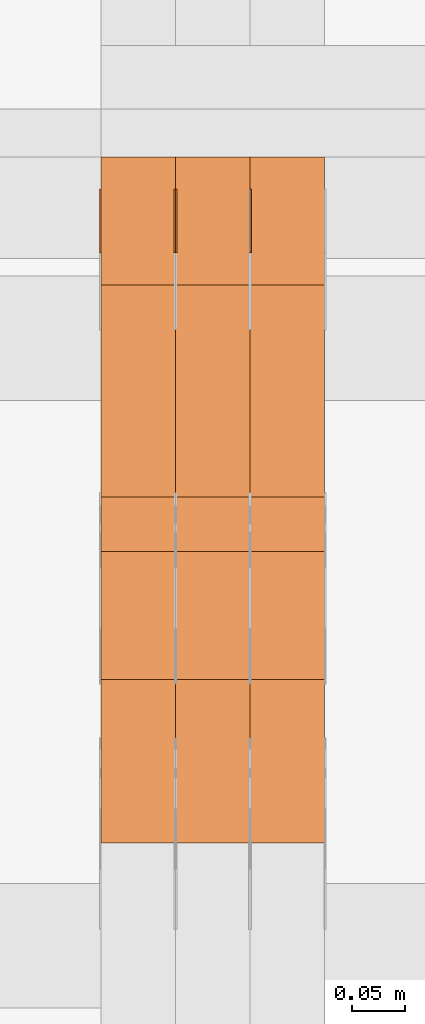
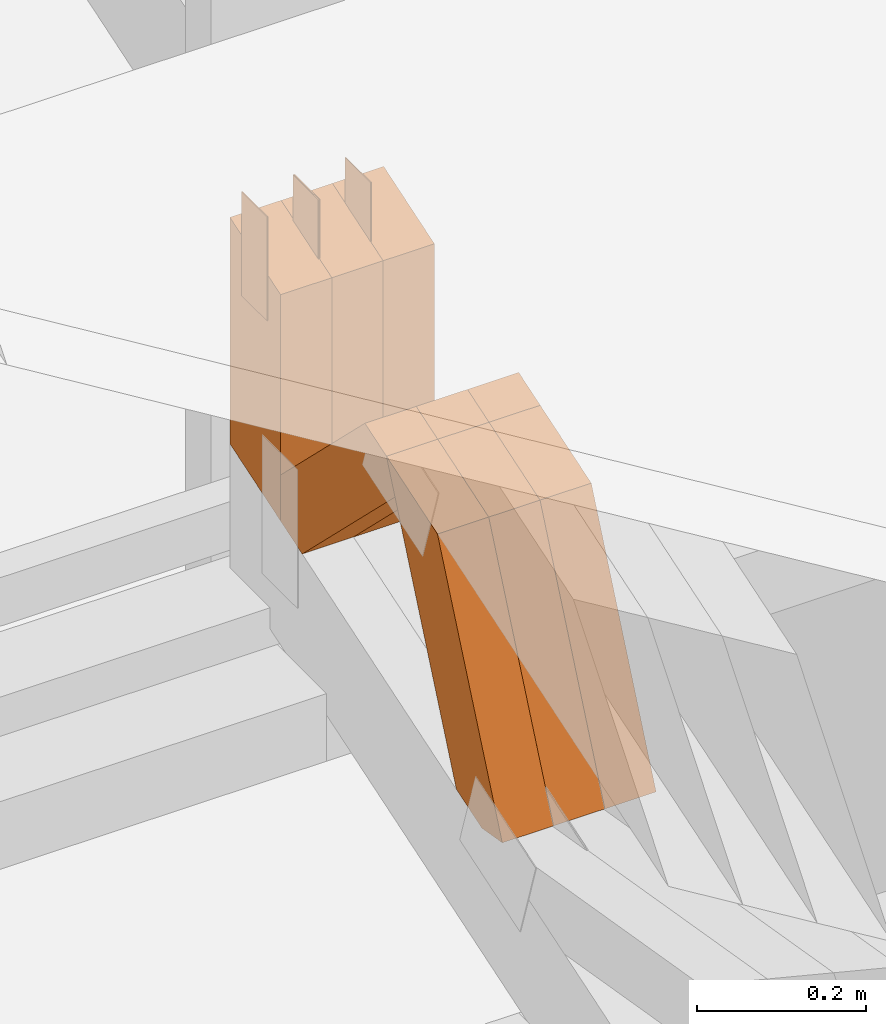
# One storey, part 98 of 385: 13 proxies.
"""IFC2X3 building model written with IfcOpenShell, lengths in millimetres."""

from ifc_helpers import new_model, entity, si_unit, converted_unit, derived_unit, direction, frame, origin, origin_2d_with_axis, place, context, subcontext, project, spatial, polyline, rectangle, outline, extrude, source, transform, mapped, material, type_object, type_shapes, element, save


model = new_model("IFC2X3")

# Units and contexts
model_context = context("Model", 3, precision=0.01, world=origin(), true_north=direction((6.12303176911189e-17, 1.0)))
body_context = subcontext(model_context, "Body", "Model", "MODEL_VIEW")
ifc_project = project(units=[si_unit("LENGTHUNIT", "METRE", prefix="MILLI"), si_unit("AREAUNIT", "SQUARE_METRE"), si_unit("VOLUMEUNIT", "CUBIC_METRE"), converted_unit("PLANEANGLEUNIT", "DEGREE", entity("IfcRatioMeasure", 0.0174532925199433), si_unit("PLANEANGLEUNIT", "RADIAN"), dimensions=[0, 0, 0, 0, 0, 0, 0]), si_unit("MASSUNIT", "GRAM", prefix="KILO"), derived_unit("MASSDENSITYUNIT", [(si_unit("MASSUNIT", "GRAM", prefix="KILO"), 1), (si_unit("LENGTHUNIT", "METRE"), -3)]), si_unit("TIMEUNIT", "SECOND"), si_unit("FREQUENCYUNIT", "HERTZ"), si_unit("THERMODYNAMICTEMPERATUREUNIT", "DEGREE_CELSIUS"), derived_unit("THERMALTRANSMITTANCEUNIT", [(si_unit("MASSUNIT", "GRAM", prefix="KILO"), 1), (si_unit("THERMODYNAMICTEMPERATUREUNIT", "KELVIN"), -1), (si_unit("TIMEUNIT", "SECOND"), -3)]), derived_unit("VOLUMETRICFLOWRATEUNIT", [(si_unit("LENGTHUNIT", "METRE"), 3), (si_unit("TIMEUNIT", "SECOND"), -1)]), si_unit("ELECTRICCURRENTUNIT", "AMPERE"), si_unit("ELECTRICVOLTAGEUNIT", "VOLT"), si_unit("POWERUNIT", "WATT"), si_unit("FORCEUNIT", "NEWTON", prefix="KILO"), si_unit("ILLUMINANCEUNIT", "LUX"), si_unit("LUMINOUSFLUXUNIT", "LUMEN"), si_unit("LUMINOUSINTENSITYUNIT", "CANDELA"), derived_unit("USERDEFINED", [(si_unit("MASSUNIT", "GRAM", prefix="KILO"), -1), (si_unit("LENGTHUNIT", "METRE"), -2), (si_unit("TIMEUNIT", "SECOND"), 3), (si_unit("LUMINOUSFLUXUNIT", "LUMEN"), 1)]), derived_unit("LINEARVELOCITYUNIT", [(si_unit("LENGTHUNIT", "METRE"), 1), (si_unit("TIMEUNIT", "SECOND"), -1)]), si_unit("PRESSUREUNIT", "PASCAL"), derived_unit("USERDEFINED", [(si_unit("LENGTHUNIT", "METRE"), -2), (si_unit("MASSUNIT", "GRAM", prefix="KILO"), 1), (si_unit("TIMEUNIT", "SECOND"), -2)])], contexts=[model_context])

# Site, building, storey
site_placement = place(None, origin())
site = spatial("IfcSite", under=ifc_project, at=site_placement, CompositionType="ELEMENT")
building_placement = place(site_placement, origin())
building = spatial("IfcBuilding", under=site, at=building_placement, CompositionType="ELEMENT")
storey_placement = place(building_placement, origin())
storey = spatial("IfcBuildingStorey", under=building, at=storey_placement, Name="Default", CompositionType="ELEMENT", Elevation=0.0)

# Proxies
ifc_material_1 = material(Name="IfcSurfaceStyle #200134")
building_element_proxy_type_1 = type_object("IfcBuildingElementProxyType", PredefinedType="NOTDEFINED", material=ifc_material_1)
shared_shape_1 = source(origin(), body_context, "Body", "SweptSolid", [
    extrude(rectangle(XDim=150.0, YDim=60.0, at=origin_2d_with_axis()), frame((75.0000705696166, 30.0, 0.0), z_axis=(0.0, 0.0, 1.0), x_axis=(-1.0, 0.0, 0.0)), (0.0, 0.0, 1.0), 1.3),
])
type_shapes(building_element_proxy_type_1, [shared_shape_1])
proxy_1_placement = place(building_placement, frame((15316.3, 13750.0, 3972.59919166337), z_axis=(-1.0, 0.0, 0.0), x_axis=(0.0, 0.0, -1.0)))
element("IfcBuildingElementProxy", 1, at=proxy_1_placement, inside=storey, type_object=building_element_proxy_type_1, material=ifc_material_1, context=body_context, shape_type="MappedRepresentation", body=[
    mapped(shared_shape_1, transform((0.0, 0.0, 0.0), scale=1.0)),
])
ifc_material_2 = material(Name="IfcSurfaceStyle #200077")
building_element_proxy_type_2 = type_object("IfcBuildingElementProxyType", PredefinedType="NOTDEFINED", material=ifc_material_2)
shared_shape_2 = source(origin(), body_context, "Body", "SweptSolid", [
    extrude(rectangle(XDim=150.0, YDim=60.0, at=origin_2d_with_axis()), frame((75.0000705696166, 30.0, 0.0), z_axis=(0.0, 0.0, 1.0), x_axis=(-1.0, 0.0, 0.0)), (0.0, 0.0, 1.0), 1.29999999999999),
])
type_shapes(building_element_proxy_type_2, [shared_shape_2])
proxy_2_placement = place(building_placement, frame((15245.0, 13750.0, 3972.59919166337), z_axis=(-1.0, 0.0, 0.0), x_axis=(0.0, 0.0, -1.0)))
element("IfcBuildingElementProxy", 2, at=proxy_2_placement, inside=storey, type_object=building_element_proxy_type_2, material=ifc_material_2, context=body_context, shape_type="MappedRepresentation", body=[
    mapped(shared_shape_2, transform((0.0, 0.0, 0.0), scale=1.0)),
])
ifc_material_3 = material(Name="IfcSurfaceStyle #200020")
building_element_proxy_type_3 = type_object("IfcBuildingElementProxyType", PredefinedType="NOTDEFINED", material=ifc_material_3)
shared_shape_3 = source(origin(), body_context, "Body", "SweptSolid", [
    extrude(rectangle(XDim=150.0, YDim=60.0, at=origin_2d_with_axis()), frame((75.0000705696166, 30.0, 0.0), z_axis=(0.0, 0.0, 1.0), x_axis=(-1.0, 0.0, 0.0)), (0.0, 0.0, 1.0), 1.29999999999999),
])
type_shapes(building_element_proxy_type_3, [shared_shape_3])
proxy_3_placement = place(building_placement, frame((15246.3, 13750.0, 3972.59919166337), z_axis=(-1.0, 0.0, 0.0), x_axis=(0.0, 0.0, -1.0)))
element("IfcBuildingElementProxy", 3, at=proxy_3_placement, inside=storey, type_object=building_element_proxy_type_3, material=ifc_material_3, context=body_context, shape_type="MappedRepresentation", body=[
    mapped(shared_shape_3, transform((0.0, 0.0, 0.0), scale=1.0)),
])
ifc_material_4 = material(Name="IfcSurfaceStyle #199963")
building_element_proxy_type_4 = type_object("IfcBuildingElementProxyType", PredefinedType="NOTDEFINED", material=ifc_material_4)
shared_shape_4 = source(origin(), body_context, "Body", "SweptSolid", [
    extrude(rectangle(XDim=150.0, YDim=60.0, at=origin_2d_with_axis()), frame((75.0000705696166, 30.0, 0.0), z_axis=(0.0, 0.0, 1.0), x_axis=(-1.0, 0.0, 0.0)), (0.0, 0.0, 1.0), 1.29999999999999),
])
type_shapes(building_element_proxy_type_4, [shared_shape_4])
proxy_4_placement = place(building_placement, frame((15175.0, 13750.0, 3972.59919166337), z_axis=(-1.0, 0.0, 0.0), x_axis=(0.0, 0.0, -1.0)))
element("IfcBuildingElementProxy", 4, at=proxy_4_placement, inside=storey, type_object=building_element_proxy_type_4, material=ifc_material_4, context=body_context, shape_type="MappedRepresentation", body=[
    mapped(shared_shape_4, transform((0.0, 0.0, 0.0), scale=1.0)),
])
ifc_material_5 = material(Name="IfcSurfaceStyle #190762")
building_element_proxy_type_5 = type_object("IfcBuildingElementProxyType", Name="T1-W49 190760", PredefinedType="NOTDEFINED", material=ifc_material_5)
shared_shape_5 = source(origin(), body_context, "Body", "SweptSolid", [
    extrude(outline(polyline([(-155.175867306415, -47.4997478409253), (152.310664695054, -47.4997478409253), (170.496756790954, -6.14570120142345e-05), (145.70957993751, 47.4998092979374), (-133.37808995724, 47.4998092979373), (-179.963044159863, -6.14570120298391e-05), (-155.175867306415, -47.4997478409253)])), frame((170.496756790954, 47.5001152140455, 0.0), z_axis=(0.0, 0.0, 1.0), x_axis=(-1.0, 0.0, 0.0)), (0.0, 0.0, 1.0), 70.0),
])
type_shapes(building_element_proxy_type_5, [shared_shape_5])
proxy_5_placement = place(building_placement, frame((15385.0, 13443.048524104, 3830.71841973934), z_axis=(-1.0, 0.0, 0.0), x_axis=(0.0, 0.713950095632063, -0.700196587357413)))
element("IfcBuildingElementProxy", 5, at=proxy_5_placement, inside=storey, type_object=building_element_proxy_type_5, material=ifc_material_5, Name="T1-W49", context=body_context, shape_type="MappedRepresentation", body=[
    mapped(shared_shape_5, transform((0.0, 0.0, 0.0), scale=1.0)),
])
ifc_material_6 = material(Name="IfcSurfaceStyle #190687")
building_element_proxy_type_6 = type_object("IfcBuildingElementProxyType", Name="T1-W49 190685", PredefinedType="NOTDEFINED", material=ifc_material_6)
shared_shape_6 = source(origin(), body_context, "Body", "SweptSolid", [
    extrude(outline(polyline([(-155.175867306415, -47.4997478409253), (152.310664695054, -47.4997478409253), (170.496756790954, -6.14570120142345e-05), (145.70957993751, 47.4998092979374), (-133.37808995724, 47.4998092979373), (-179.963044159863, -6.14570120298391e-05), (-155.175867306415, -47.4997478409253)])), frame((170.496756790954, 47.5001152140455, 0.0), z_axis=(0.0, 0.0, 1.0), x_axis=(-1.0, 0.0, 0.0)), (0.0, 0.0, 1.0), 70.0),
])
type_shapes(building_element_proxy_type_6, [shared_shape_6])
proxy_6_placement = place(building_placement, frame((15315.0, 13443.048524104, 3830.71841973934), z_axis=(-1.0, 0.0, 0.0), x_axis=(0.0, 0.713950095632063, -0.700196587357413)))
element("IfcBuildingElementProxy", 6, at=proxy_6_placement, inside=storey, type_object=building_element_proxy_type_6, material=ifc_material_6, Name="T1-W49", context=body_context, shape_type="MappedRepresentation", body=[
    mapped(shared_shape_6, transform((0.0, 0.0, 0.0), scale=1.0)),
])
ifc_material_7 = material(Name="IfcSurfaceStyle #190612")
building_element_proxy_type_7 = type_object("IfcBuildingElementProxyType", Name="T1-W49 190610", PredefinedType="NOTDEFINED", material=ifc_material_7)
shared_shape_7 = source(origin(), body_context, "Body", "SweptSolid", [
    extrude(outline(polyline([(-155.175867306415, -47.4997478409253), (152.310664695054, -47.4997478409253), (170.496756790954, -6.14570120142345e-05), (145.70957993751, 47.4998092979374), (-133.37808995724, 47.4998092979373), (-179.963044159863, -6.14570120298391e-05), (-155.175867306415, -47.4997478409253)])), frame((170.496756790954, 47.5001152140455, 0.0), z_axis=(0.0, 0.0, 1.0), x_axis=(-1.0, 0.0, 0.0)), (0.0, 0.0, 1.0), 70.0),
])
type_shapes(building_element_proxy_type_7, [shared_shape_7])
proxy_7_placement = place(building_placement, frame((15245.0, 13443.048524104, 3830.71841973934), z_axis=(-1.0, 0.0, 0.0), x_axis=(0.0, 0.713950095632063, -0.700196587357413)))
element("IfcBuildingElementProxy", 7, at=proxy_7_placement, inside=storey, type_object=building_element_proxy_type_7, material=ifc_material_7, Name="T1-W49", context=body_context, shape_type="MappedRepresentation", body=[
    mapped(shared_shape_7, transform((0.0, 0.0, 0.0), scale=1.0)),
])
ifc_material_8 = material(Name="IfcSurfaceStyle #190312")
building_element_proxy_type_8 = type_object("IfcBuildingElementProxyType", Name="T1-W1 190310", PredefinedType="NOTDEFINED", material=ifc_material_8)
shared_shape_8 = source(origin(), body_context, "Body", "SweptSolid", [
    extrude(outline(polyline([(-182.839782714844, -60.0), (143.849426269531, -60.0), (182.839660644531, 60.0), (-143.849304199219, 60.0), (-182.839782714844, -60.0)])), frame((182.839674685549, 60.0, 0.0), z_axis=(0.0, 0.0, 1.0), x_axis=(-1.0, 0.0, 0.0)), (0.0, 0.0, 1.0), 70.0),
])
type_shapes(building_element_proxy_type_8, [shared_shape_8])
proxy_8_placement = place(building_placement, frame((15385.0, 13660.0, 3551.41502502148), z_axis=(-1.0, 0.0, 0.0), x_axis=(0.0, 0.0, 1.0)))
element("IfcBuildingElementProxy", 8, at=proxy_8_placement, inside=storey, type_object=building_element_proxy_type_8, material=ifc_material_8, Name="T1-W1", context=body_context, shape_type="MappedRepresentation", body=[
    mapped(shared_shape_8, transform((0.0, 0.0, 0.0), scale=1.0)),
])
ifc_material_9 = material(Name="IfcSurfaceStyle #190255")
building_element_proxy_type_9 = type_object("IfcBuildingElementProxyType", Name="T1-W1 190253", PredefinedType="NOTDEFINED", material=ifc_material_9)
shared_shape_9 = source(origin(), body_context, "Body", "SweptSolid", [
    extrude(outline(polyline([(-182.839782714844, -60.0), (143.849426269531, -60.0), (182.839660644531, 60.0), (-143.849304199219, 60.0), (-182.839782714844, -60.0)])), frame((182.839674685549, 60.0, 0.0), z_axis=(0.0, 0.0, 1.0), x_axis=(-1.0, 0.0, 0.0)), (0.0, 0.0, 1.0), 70.0),
])
type_shapes(building_element_proxy_type_9, [shared_shape_9])
proxy_9_placement = place(building_placement, frame((15315.0, 13660.0, 3551.41502502148), z_axis=(-1.0, 0.0, 0.0), x_axis=(0.0, 0.0, 1.0)))
element("IfcBuildingElementProxy", 9, at=proxy_9_placement, inside=storey, type_object=building_element_proxy_type_9, material=ifc_material_9, Name="T1-W1", context=body_context, shape_type="MappedRepresentation", body=[
    mapped(shared_shape_9, transform((0.0, 0.0, 0.0), scale=1.0)),
])
ifc_material_10 = material(Name="IfcSurfaceStyle #190198")
building_element_proxy_type_10 = type_object("IfcBuildingElementProxyType", Name="T1-W1 190196", PredefinedType="NOTDEFINED", material=ifc_material_10)
shared_shape_10 = source(origin(), body_context, "Body", "SweptSolid", [
    extrude(outline(polyline([(-182.839782714844, -60.0), (143.849426269531, -60.0), (182.839660644531, 60.0), (-143.849304199219, 60.0), (-182.839782714844, -60.0)])), frame((182.839674685549, 60.0, 0.0), z_axis=(0.0, 0.0, 1.0), x_axis=(-1.0, 0.0, 0.0)), (0.0, 0.0, 1.0), 70.0),
])
type_shapes(building_element_proxy_type_10, [shared_shape_10])
proxy_10_placement = place(building_placement, frame((15245.0, 13660.0, 3551.41502502148), z_axis=(-1.0, 0.0, 0.0), x_axis=(0.0, 0.0, 1.0)))
element("IfcBuildingElementProxy", 10, at=proxy_10_placement, inside=storey, type_object=building_element_proxy_type_10, material=ifc_material_10, Name="T1-W1", context=body_context, shape_type="MappedRepresentation", body=[
    mapped(shared_shape_10, transform((0.0, 0.0, 0.0), scale=1.0)),
])
ifc_material_11 = material(Name="IfcSurfaceStyle #189772")
building_element_proxy_type_11 = type_object("IfcBuildingElementProxyType", Name="T1-W42 189770", PredefinedType="NOTDEFINED", material=ifc_material_11)
shared_shape_11 = source(origin(), body_context, "Body", "SweptSolid", [
    extrude(outline(polyline([(-284.837590197601, -47.4997543607933), (129.95880168156, -47.4997543607933), (171.972324990451, 0.000162623346093338), (183.717007105413, 47.4996730491203), (-200.810543579822, 47.4996730491203), (-284.837590197601, -47.4997543607933)])), frame((183.717155718752, 47.4999821655365, 0.0), z_axis=(0.0, 0.0, 1.0), x_axis=(-1.0, 0.0, 0.0)), (0.0, 0.0, 1.0), 70.0),
])
type_shapes(building_element_proxy_type_11, [shared_shape_11])
proxy_11_placement = place(building_placement, frame((15385.0, 13135.8834463264, 3404.958483022), z_axis=(-1.0, 0.0, 0.0), x_axis=(0.0, 0.398630596470292, 0.917111578575769)))
element("IfcBuildingElementProxy", 11, at=proxy_11_placement, inside=storey, type_object=building_element_proxy_type_11, material=ifc_material_11, Name="T1-W42", context=body_context, shape_type="MappedRepresentation", body=[
    mapped(shared_shape_11, transform((0.0, 0.0, 0.0), scale=1.0)),
])
ifc_material_12 = material(Name="IfcSurfaceStyle #189706")
building_element_proxy_type_12 = type_object("IfcBuildingElementProxyType", Name="T1-W42 189704", PredefinedType="NOTDEFINED", material=ifc_material_12)
shared_shape_12 = source(origin(), body_context, "Body", "SweptSolid", [
    extrude(outline(polyline([(-284.837590197601, -47.4997543607933), (129.95880168156, -47.4997543607933), (171.972324990451, 0.000162623346093338), (183.717007105413, 47.4996730491203), (-200.810543579822, 47.4996730491203), (-284.837590197601, -47.4997543607933)])), frame((183.717155718752, 47.4999821655365, 0.0), z_axis=(0.0, 0.0, 1.0), x_axis=(-1.0, 0.0, 0.0)), (0.0, 0.0, 1.0), 70.0),
])
type_shapes(building_element_proxy_type_12, [shared_shape_12])
proxy_12_placement = place(building_placement, frame((15315.0, 13135.8834463264, 3404.958483022), z_axis=(-1.0, 0.0, 0.0), x_axis=(0.0, 0.398630596470292, 0.917111578575769)))
element("IfcBuildingElementProxy", 12, at=proxy_12_placement, inside=storey, type_object=building_element_proxy_type_12, material=ifc_material_12, Name="T1-W42", context=body_context, shape_type="MappedRepresentation", body=[
    mapped(shared_shape_12, transform((0.0, 0.0, 0.0), scale=1.0)),
])
ifc_material_13 = material(Name="IfcSurfaceStyle #189640")
building_element_proxy_type_13 = type_object("IfcBuildingElementProxyType", Name="T1-W42 189638", PredefinedType="NOTDEFINED", material=ifc_material_13)
shared_shape_13 = source(origin(), body_context, "Body", "SweptSolid", [
    extrude(outline(polyline([(-284.837590197601, -47.4997543607933), (129.95880168156, -47.4997543607933), (171.972324990451, 0.000162623346093338), (183.717007105413, 47.4996730491203), (-200.810543579822, 47.4996730491203), (-284.837590197601, -47.4997543607933)])), frame((183.717155718752, 47.4999821655365, 0.0), z_axis=(0.0, 0.0, 1.0), x_axis=(-1.0, 0.0, 0.0)), (0.0, 0.0, 1.0), 70.0),
])
type_shapes(building_element_proxy_type_13, [shared_shape_13])
proxy_13_placement = place(building_placement, frame((15245.0, 13135.8834463264, 3404.958483022), z_axis=(-1.0, 0.0, 0.0), x_axis=(0.0, 0.398630596470292, 0.917111578575769)))
element("IfcBuildingElementProxy", 13, at=proxy_13_placement, inside=storey, type_object=building_element_proxy_type_13, material=ifc_material_13, Name="T1-W42", context=body_context, shape_type="MappedRepresentation", body=[
    mapped(shared_shape_13, transform((0.0, 0.0, 0.0), scale=1.0)),
])

save(model, "model.ifc")
